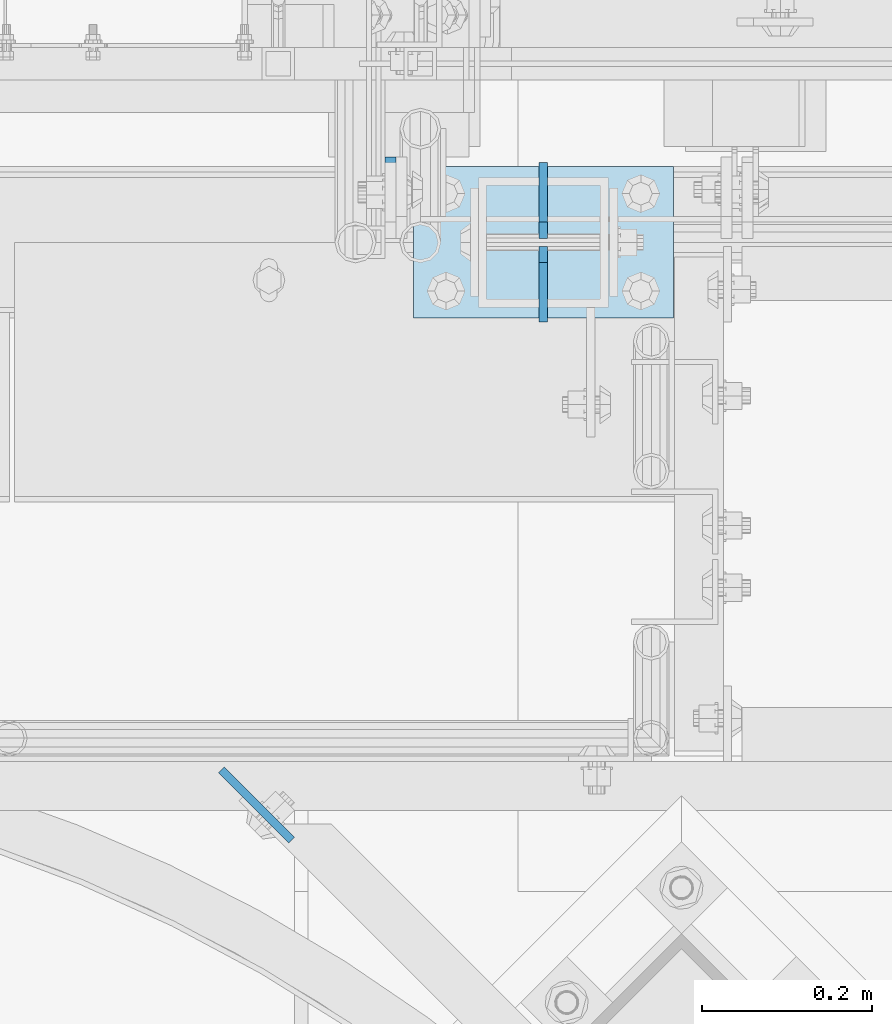
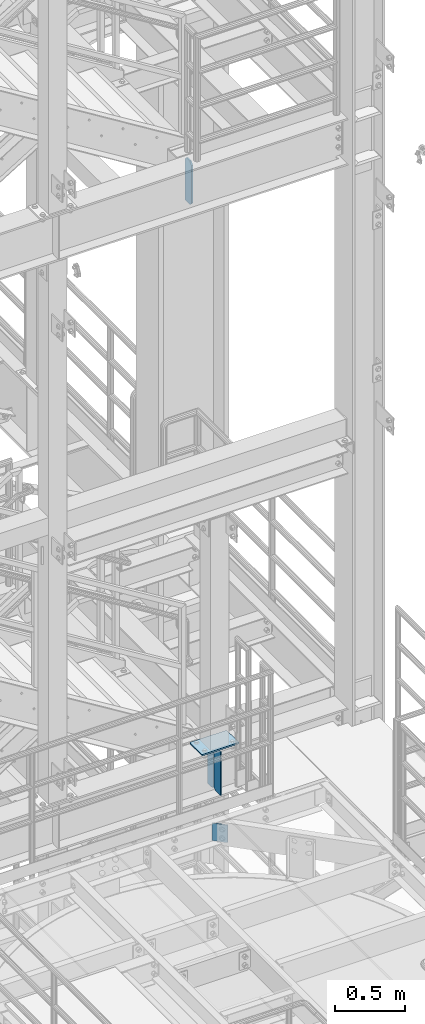
# One storey, part 1451 of 1876: 5 plates, 4 elements without a shape of their own.
"""IFC2X3 building model written with IfcOpenShell, lengths in millimetres."""

from ifc_helpers import new_model, si_unit, frame, origin_with_axes, place, context, subcontext, project, spatial, faceted_brep, material, type_object, element, aggregate, save


model = new_model("IFC2X3")

# Units and contexts
model_context = context("Model", 3, precision=1e-05, world=origin_with_axes())
body_context = subcontext(model_context, "Body", "Model", "MODEL_VIEW")
ifc_project = project(units=[si_unit("LENGTHUNIT", "METRE", prefix="MILLI"), si_unit("AREAUNIT", "SQUARE_METRE"), si_unit("VOLUMEUNIT", "CUBIC_METRE"), si_unit("MASSUNIT", "GRAM", prefix="KILO"), si_unit("TIMEUNIT", "SECOND"), si_unit("PLANEANGLEUNIT", "RADIAN"), si_unit("SOLIDANGLEUNIT", "STERADIAN"), si_unit("THERMODYNAMICTEMPERATUREUNIT", "DEGREE_CELSIUS"), si_unit("LUMINOUSINTENSITYUNIT", "LUMEN")], contexts=[model_context])

# Site, building, storey
site_placement = place(None, origin_with_axes())
site = spatial("IfcSite", under=ifc_project, at=site_placement, CompositionType="ELEMENT")
building_placement = place(site_placement, origin_with_axes())
building = spatial("IfcBuilding", under=site, at=building_placement, Name="Undefined", CompositionType="ELEMENT")
storey_placement = place(building_placement, origin_with_axes())
storey = spatial("IfcBuildingStorey", under=building, at=storey_placement, Name="Undefined", CompositionType="ELEMENT", Elevation=0.0)

# Assembly, plate
assembly_1_placement = place(storey_placement, origin_with_axes())
assembly_1 = element("IfcElementAssembly", 1, at=assembly_1_placement, inside=storey, Name="COLUMN", AssemblyPlace="NOTDEFINED", PredefinedType="RIGID_FRAME")
ifc_material = material(Name="STEEL/A36")
plate_type_1 = type_object("IfcPlateType", PredefinedType="NOTDEFINED")
plate_1_placement = place(assembly_1_placement, frame((6570.6625, -7200.9, 8159.75), z_axis=(-1.0, 0.0, 0.0), x_axis=(0.0, 1.0, 0.0)))
plate_1 = element("IfcPlate", 2, at=plate_1_placement, type_object=plate_type_1, material=ifc_material, Name="PLATE", context=body_context, shape_type="Brep", body=[
    faceted_brep([(0.0, -6.35000000000036, 0.0), (0.0, -6.35000000000036, 304.799987792969), (0.0, 6.35000000000036, 304.799987792969), (0.0, 6.35000000000036, 0.0), (177.800003051758, -6.35000000000036, 304.799987792969), (177.800003051758, 6.35000000000036, 304.799987792969), (177.800003051758, -6.35000000000036, 0.0), (177.800003051758, 6.35000000000036, 0.0)], [[[0, 1, 2, 3]], [[1, 4, 5, 2]], [[4, 6, 7, 5]], [[6, 0, 3, 7]], [[5, 7, 3, 2]], [[6, 4, 1, 0]]]),
])
aggregate(assembly_1, [plate_1])

# Assembly, plates
assembly_2_placement = place(storey_placement, origin_with_axes())
assembly_2 = element("IfcElementAssembly", 3, at=assembly_2_placement, inside=storey, Name="BEAM", AssemblyPlace="NOTDEFINED", PredefinedType="RIGID_FRAME")
plate_type_2 = type_object("IfcPlateType", PredefinedType="NOTDEFINED")
plate_2_placement = place(assembly_2_placement, frame((6417.97675401922, -7205.6625, 7758.1125), z_axis=(0.0, 0.0, 1.0), x_axis=(0.0, 1.0, 0.0)))
plate_2 = element("IfcPlate", 4, at=plate_2_placement, type_object=plate_type_2, material=ifc_material, Name="PLATE", context=body_context, shape_type="Brep", body=[
    faceted_brep([(0.0, -4.76249999999982, 0.0), (0.0, -4.76250000000073, 381.0), (0.0, 4.76250000000073, 381.0), (0.0, 4.76249999999982, 0.0), (69.8500022888184, -4.76249999999982, 381.0), (69.8500022888184, 4.76249999999982, 381.0), (88.9000015258789, -4.76249999999982, 361.950000762939), (88.9000015258789, 4.76249999999982, 361.950000762939), (88.9000015258789, -4.76249999999982, 19.0499992370605), (88.9000015258789, 4.76249999999982, 19.0499992370605), (69.8500022888184, -4.76249999999982, 0.0), (69.8500022888184, 4.76249999999982, 0.0)], [[[0, 1, 2, 3]], [[1, 4, 5, 2]], [[4, 6, 7, 5]], [[6, 8, 9, 7]], [[8, 10, 11, 9]], [[10, 0, 3, 11]], [[5, 7, 9, 11, 3, 2]], [[10, 8, 6, 4, 1, 0]]]),
])
plate_3_placement = place(assembly_2_placement, frame((6417.97675401922, -7107.2375, 7758.1125), z_axis=(0.0, 0.0, 1.0), x_axis=(0.0, 1.0, 0.0)))
plate_3 = element("IfcPlate", 5, at=plate_3_placement, type_object=plate_type_2, material=ifc_material, Name="PLATE", context=body_context, shape_type="Brep", body=[
    faceted_brep([(0.0, -4.76249999999982, 19.0499992370605), (0.0, -4.76249999999982, 361.950000762939), (0.0, 4.76249999999982, 361.950000762939), (0.0, 4.76249999999982, 19.0499992370605), (19.0499992370605, -4.76249999999982, 381.0), (19.0499992370605, 4.76249999999982, 381.0), (88.9000015258789, -4.76249999999982, 381.0), (88.9000015258789, 4.76249999999982, 381.0), (88.9000015258789, -4.76249999999982, 0.0), (88.9000015258789, 4.76249999999982, 0.0), (19.0499992370605, -4.76249999999982, 0.0), (19.0499992370605, 4.76249999999982, 0.0)], [[[0, 1, 2, 3]], [[1, 4, 5, 2]], [[4, 6, 7, 5]], [[6, 8, 9, 7]], [[8, 10, 11, 9]], [[10, 0, 3, 11]], [[5, 7, 9, 11, 3, 2]], [[10, 8, 6, 4, 1, 0]]]),
])
aggregate(assembly_2, [plate_2, plate_3])

# Assembly, plate
assembly_3_placement = place(storey_placement, origin_with_axes())
assembly_3 = element("IfcElementAssembly", 6, at=assembly_3_placement, inside=storey, Name="BEAM", AssemblyPlace="NOTDEFINED", PredefinedType="RIGID_FRAME")
plate_type_3 = type_object("IfcPlateType", PredefinedType="NOTDEFINED")
plate_4_placement = place(assembly_3_placement, frame((6040.27258310378, -7731.28200034104, 7972.425), z_axis=(0.707106781186547, -0.707106781186548, 0.0), x_axis=(0.0, 0.0, -1.0)))
plate_4 = element("IfcPlate", 7, at=plate_4_placement, type_object=plate_type_3, material=ifc_material, Name="PLATE", context=body_context, shape_type="Brep", body=[
    faceted_brep([(0.0, -4.76249999999982, 0.0), (0.0, -4.76249999999891, 116.385513305684), (0.0, 4.76250000000255, 116.385513305684), (0.0, 4.76249999999982, 0.0), (152.399993896484, -4.76249999999891, 116.385513305684), (152.399993896484, 4.76250000000255, 116.385513305684), (152.399993896484, -4.76249999999982, 0.0), (152.399993896484, 4.76249999999982, 0.0)], [[[0, 1, 2, 3]], [[1, 4, 5, 2]], [[4, 6, 7, 5]], [[6, 0, 3, 7]], [[5, 7, 3, 2]], [[6, 4, 1, 0]]]),
])
aggregate(assembly_3, [plate_4])

assembly_4_placement = place(storey_placement, origin_with_axes())
assembly_4 = element("IfcElementAssembly", 8, at=assembly_4_placement, inside=storey, Name="BEAM", AssemblyPlace="NOTDEFINED", PredefinedType="RIGID_FRAME")
plate_type_4 = type_object("IfcPlateType", PredefinedType="NOTDEFINED")
plate_5_placement = place(assembly_4_placement, frame((6238.87499990463, -7107.2375, 12915.9), z_axis=(0.0, 0.0, 1.0), x_axis=(0.0, 1.0, 0.0)))
plate_5 = element("IfcPlate", 9, at=plate_5_placement, type_object=plate_type_4, material=ifc_material, Name="PLATE", context=body_context, shape_type="Brep", body=[
    faceted_brep([(0.0, -6.35000000000036, 25.4000000000005), (0.0, -6.35000000000036, 354.012506484985), (0.0, 6.35000000000036, 354.012506484985), (0.0, 6.35000000000036, 25.4000000000005), (25.3999996185303, -6.35000000000036, 379.412506103516), (25.3999996185303, 6.35000000000036, 379.412506103516), (76.2000007629395, -6.35000000000036, 379.412506103516), (76.2000007629395, 6.35000000000036, 379.412506103516), (95.25, -6.35000000000036, 360.362506866455), (95.25, 6.35000000000036, 360.362506866455), (95.25, -6.35000000000036, 0.0), (95.25, 6.35000000000036, 0.0), (25.3999996185303, -6.34999999999991, 0.0), (25.3999996185303, 6.34999999999991, 0.0)], [[[0, 1, 2, 3]], [[1, 4, 5, 2]], [[4, 6, 7, 5]], [[6, 8, 9, 7]], [[8, 10, 11, 9]], [[10, 12, 13, 11]], [[12, 0, 3, 13]], [[5, 7, 9, 11, 13, 3, 2]], [[12, 10, 8, 6, 4, 1, 0]]]),
])
aggregate(assembly_4, [plate_5])

save(model, "model.ifc")
